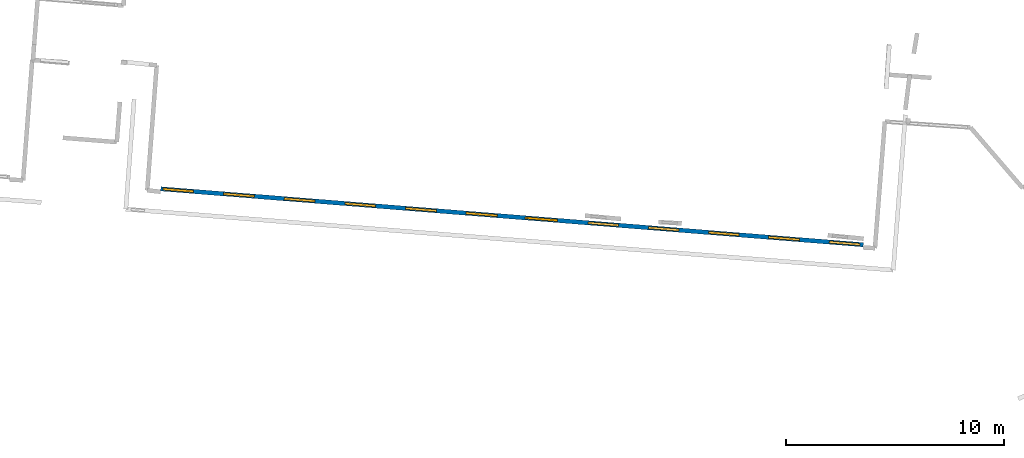
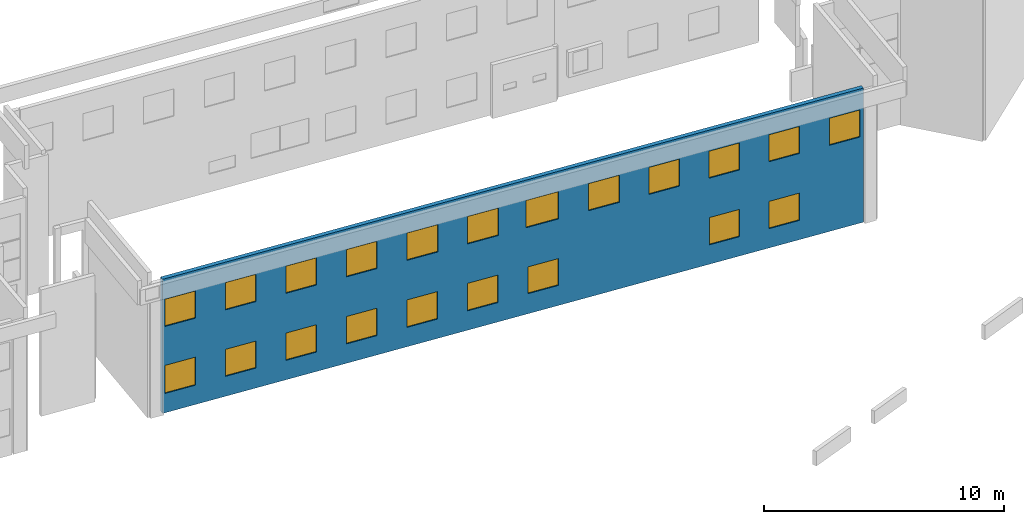
# One storey, part 18 of 27: 21 windows, 1 wall, 21 openings.
"""IFC2X3 building model written with IfcOpenShell, lengths in metres."""

from ifc_helpers import new_model, entity, si_unit, converted_unit, derived_unit, direction, frame, frame_2d, origin, origin_2d_with_axis, place, context, subcontext, project, spatial, polyline, rectangle, outline, extrude, source, transform, mapped, material, layer, layer_set, layer_usage, type_object, type_shapes, element, fill, save


model = new_model("IFC2X3")

# Units and contexts
model_context = context("Model", 3, precision=1e-05, world=origin(), true_north=direction((0.0, 1.0)))
body_context = subcontext(model_context, "Body", "Model", "MODEL_VIEW")
ifc_project = project(units=[si_unit("LENGTHUNIT", "METRE"), si_unit("AREAUNIT", "SQUARE_METRE"), si_unit("VOLUMEUNIT", "CUBIC_METRE"), converted_unit("PLANEANGLEUNIT", "DEGREE", entity("IfcRatioMeasure", 0.0174532925199433), si_unit("PLANEANGLEUNIT", "RADIAN"), dimensions=[0, 0, 0, 0, 0, 0, 0]), si_unit("MASSUNIT", "GRAM", prefix="KILO"), derived_unit("MASSDENSITYUNIT", [(si_unit("MASSUNIT", "GRAM", prefix="KILO"), 1), (si_unit("LENGTHUNIT", "METRE"), -3)]), derived_unit("MOMENTOFINERTIAUNIT", [(si_unit("LENGTHUNIT", "METRE"), 4)]), si_unit("TIMEUNIT", "SECOND"), si_unit("FREQUENCYUNIT", "HERTZ"), si_unit("THERMODYNAMICTEMPERATUREUNIT", "DEGREE_CELSIUS"), derived_unit("THERMALTRANSMITTANCEUNIT", [(si_unit("MASSUNIT", "GRAM", prefix="KILO"), 1), (si_unit("THERMODYNAMICTEMPERATUREUNIT", "KELVIN"), -1), (si_unit("TIMEUNIT", "SECOND"), -3)]), derived_unit("VOLUMETRICFLOWRATEUNIT", [(si_unit("LENGTHUNIT", "METRE"), 3), (si_unit("TIMEUNIT", "SECOND"), -1)]), si_unit("ELECTRICCURRENTUNIT", "AMPERE"), si_unit("ELECTRICVOLTAGEUNIT", "VOLT"), si_unit("POWERUNIT", "WATT"), si_unit("FORCEUNIT", "NEWTON", prefix="KILO"), si_unit("ILLUMINANCEUNIT", "LUX"), si_unit("LUMINOUSFLUXUNIT", "LUMEN"), si_unit("LUMINOUSINTENSITYUNIT", "CANDELA"), derived_unit("USERDEFINED", [(si_unit("MASSUNIT", "GRAM", prefix="KILO"), -1), (si_unit("LENGTHUNIT", "METRE"), -2), (si_unit("TIMEUNIT", "SECOND"), 3), (si_unit("LUMINOUSFLUXUNIT", "LUMEN"), 1)]), derived_unit("LINEARVELOCITYUNIT", [(si_unit("LENGTHUNIT", "METRE"), 1), (si_unit("TIMEUNIT", "SECOND"), -1)]), si_unit("PRESSUREUNIT", "PASCAL"), derived_unit("USERDEFINED", [(si_unit("LENGTHUNIT", "METRE"), -2), (si_unit("MASSUNIT", "GRAM", prefix="KILO"), 1), (si_unit("TIMEUNIT", "SECOND"), -2)]), derived_unit("LINEARFORCEUNIT", [(si_unit("MASSUNIT", "GRAM", prefix="KILO"), 1), (si_unit("LENGTHUNIT", "METRE"), 1), (si_unit("TIMEUNIT", "SECOND"), -2), (si_unit("LENGTHUNIT", "METRE"), -1)]), derived_unit("PLANARFORCEUNIT", [(si_unit("MASSUNIT", "GRAM", prefix="KILO"), 1), (si_unit("LENGTHUNIT", "METRE"), 1), (si_unit("TIMEUNIT", "SECOND"), -2), (si_unit("LENGTHUNIT", "METRE"), -2)])], contexts=[model_context])

# Site, building, storey
placement = place(None, origin())
site = spatial("IfcSite", under=ifc_project, at=placement, CompositionType="ELEMENT")
building = spatial("IfcBuilding", under=site, at=placement, CompositionType="ELEMENT")
storey_placement = place(placement, frame((0.0, 0.0, -61.043098449707)))
storey = spatial("IfcBuildingStorey", under=building, at=storey_placement, Name="level_-61.043098", CompositionType="ELEMENT", Elevation=-61.043098449707)

# Wall, openings, windows
ifc_material_1 = material(Name="Default wall")
ifc_layer = layer(ifc_material_1, 0.2)
ifc_layer_set = layer_set([ifc_layer], Name="wall_thickness_0.2000")
ifc_layer_usage = layer_usage(ifc_layer_set, "AXIS2", "POSITIVE", -0.1)
wall_type = type_object("IfcWallType", Name="wall_thickness_0.2000", PredefinedType="STANDARD", material=ifc_layer_set)
wall_placement = place(storey_placement, frame((-30.6934941233889, -16.4458057543927, 0.0), z_axis=(0.0, 0.0, 1.0), x_axis=(0.996845104750756, -0.0793715133688069, 0.0)))
wall = element("IfcWallStandardCase", 1, at=wall_placement, inside=storey, type_object=wall_type, material=ifc_layer_usage, Name="Wall:955", ObjectType="Wall", context=body_context, shape_type="SweptSolid", body=[
    extrude(outline(polyline([(32.3901609688937, -0.1), (32.3901609688937, 0.1), (0.0, 0.1), (0.0, -0.1), (32.3901609688937, -0.1)])), origin(), (0.0, 0.0, 1.0), 6.83392333984375),
])
opening_1_placement = place(wall_placement, frame((11.2866592142444, -0.1, 0.986843109130859)))
opening_1 = element("IfcOpeningElement", 2, at=opening_1_placement, cuts=wall, Name="Opening : 1425 x 1400 : 111", ObjectType="Opening", context=body_context, shape_type="SweptSolid", body=[
    extrude(rectangle(XDim=1.425, YDim=1.4, at=frame_2d((0.7, 0.7125), x_axis=(0.0, 1.0))), frame((0.0, 0.0, 0.0), z_axis=(0.0, 1.0, 0.0), x_axis=(0.0, 0.0, 1.0)), (0.0, 0.0, 1.0), 0.2),
])
opening_2_placement = place(wall_placement, frame((5.69901006299616, -0.1, 0.989467620849609)))
opening_2 = element("IfcOpeningElement", 3, at=opening_2_placement, cuts=wall, Name="Opening : 1415 x 1390 : 112", ObjectType="Opening", context=body_context, shape_type="SweptSolid", body=[
    extrude(rectangle(XDim=1.415, YDim=1.39, at=frame_2d((0.695, 0.7075), x_axis=(0.0, 1.0))), frame((0.0, 0.0, 0.0), z_axis=(0.0, 1.0, 0.0), x_axis=(0.0, 0.0, 1.0)), (0.0, 0.0, 1.0), 0.2),
])
opening_3_placement = place(wall_placement, frame((5.69400849443347, -0.1, 4.40446853637695)))
opening_3 = element("IfcOpeningElement", 4, at=opening_3_placement, cuts=wall, Name="Opening : 1410 x 1385 : 113", ObjectType="Opening", context=body_context, shape_type="SweptSolid", body=[
    extrude(rectangle(XDim=1.41, YDim=1.385, at=frame_2d((0.6925, 0.705), x_axis=(0.0, 1.0))), frame((0.0, 0.0, 0.0), z_axis=(0.0, 1.0, 0.0), x_axis=(0.0, 0.0, 1.0)), (0.0, 0.0, 1.0), 0.2),
])
opening_4_placement = place(wall_placement, frame((0.0990633938291362, -0.1, 4.39946746826172)))
opening_4 = element("IfcOpeningElement", 5, at=opening_4_placement, cuts=wall, Name="Opening : 1410 x 1385 : 114", ObjectType="Opening", context=body_context, shape_type="SweptSolid", body=[
    extrude(rectangle(XDim=1.41, YDim=1.385, at=frame_2d((0.6925, 0.705), x_axis=(0.0, 1.0))), frame((0.0, 0.0, 0.0), z_axis=(0.0, 1.0, 0.0), x_axis=(0.0, 0.0, 1.0)), (0.0, 0.0, 1.0), 0.2),
])
opening_5_placement = place(wall_placement, frame((0.104622034484493, -0.1, 0.984470367431641)))
opening_5 = element("IfcOpeningElement", 6, at=opening_5_placement, cuts=wall, Name="Opening : 1405 x 1430 : 115", ObjectType="Opening", context=body_context, shape_type="SweptSolid", body=[
    extrude(rectangle(XDim=1.405, YDim=1.43, at=frame_2d((0.715, 0.7025), x_axis=(0.0, 1.0))), frame((0.0, 0.0, 0.0), z_axis=(0.0, 1.0, 0.0), x_axis=(0.0, 0.0, 1.0)), (0.0, 0.0, 1.0), 0.2),
])
opening_6_placement = place(wall_placement, frame((2.89900813275086, -0.1, 1.01446914672852)))
opening_6 = element("IfcOpeningElement", 7, at=opening_6_placement, cuts=wall, Name="Opening : 1415 x 1375 : 116", ObjectType="Opening", context=body_context, shape_type="SweptSolid", body=[
    extrude(rectangle(XDim=1.415, YDim=1.375, at=frame_2d((0.6875, 0.7075), x_axis=(0.0, 1.0))), frame((0.0, 0.0, 0.0), z_axis=(0.0, 1.0, 0.0), x_axis=(0.0, 0.0, 1.0)), (0.0, 0.0, 1.0), 0.2),
])
opening_7_placement = place(wall_placement, frame((2.90165812919661, -0.1, 4.4018440246582)))
opening_7 = element("IfcOpeningElement", 8, at=opening_7_placement, cuts=wall, Name="Opening : 1405 x 1390 : 117", ObjectType="Opening", context=body_context, shape_type="SweptSolid", body=[
    extrude(rectangle(XDim=1.405, YDim=1.39, at=frame_2d((0.695, 0.7025), x_axis=(0.0, 1.0))), frame((0.0, 0.0, 0.0), z_axis=(0.0, 1.0, 0.0), x_axis=(0.0, 0.0, 1.0)), (0.0, 0.0, 1.0), 0.2),
])
opening_8_placement = place(wall_placement, frame((8.49665851979337, -0.1, 4.4018440246582)))
opening_8 = element("IfcOpeningElement", 9, at=opening_8_placement, cuts=wall, Name="Opening : 1415 x 1390 : 118", ObjectType="Opening", context=body_context, shape_type="SweptSolid", body=[
    extrude(rectangle(XDim=1.415, YDim=1.39, at=frame_2d((0.695, 0.7075), x_axis=(0.0, 1.0))), frame((0.0, 0.0, 0.0), z_axis=(0.0, 1.0, 0.0), x_axis=(0.0, 0.0, 1.0)), (0.0, 0.0, 1.0), 0.2),
])
opening_9_placement = place(wall_placement, frame((11.291658881476, -0.1, 4.4018440246582)))
opening_9 = element("IfcOpeningElement", 10, at=opening_9_placement, cuts=wall, Name="Opening : 1430 x 1390 : 119", ObjectType="Opening", context=body_context, shape_type="SweptSolid", body=[
    extrude(rectangle(XDim=1.43, YDim=1.39, at=frame_2d((0.695, 0.715), x_axis=(0.0, 1.0))), frame((0.0, 0.0, 0.0), z_axis=(0.0, 1.0, 0.0), x_axis=(0.0, 0.0, 1.0)), (0.0, 0.0, 1.0), 0.2),
])
opening_10_placement = place(wall_placement, frame((14.0816575232067, -0.1, 4.39684295654297)))
opening_10 = element("IfcOpeningElement", 11, at=opening_10_placement, cuts=wall, Name="Opening : 1440 x 1395 : 120", ObjectType="Opening", context=body_context, shape_type="SweptSolid", body=[
    extrude(rectangle(XDim=1.44, YDim=1.395, at=frame_2d((0.6975, 0.72), x_axis=(0.0, 1.0))), frame((0.0, 0.0, 0.0), z_axis=(0.0, 1.0, 0.0), x_axis=(0.0, 0.0, 1.0)), (0.0, 0.0, 1.0), 0.2),
])
opening_11_placement = place(wall_placement, frame((16.7966583044675, -0.1, 4.40684509277344)))
opening_11 = element("IfcOpeningElement", 12, at=opening_11_placement, cuts=wall, Name="Opening : 1505 x 1390 : 121", ObjectType="Opening", context=body_context, shape_type="SweptSolid", body=[
    extrude(rectangle(XDim=1.505, YDim=1.39, at=frame_2d((0.695, 0.7525), x_axis=(0.0, 1.0))), frame((0.0, 0.0, 0.0), z_axis=(0.0, 1.0, 0.0), x_axis=(0.0, 0.0, 1.0)), (0.0, 0.0, 1.0), 0.2),
])
opening_12_placement = place(wall_placement, frame((19.6916569154981, -0.1, 4.40684509277344)))
opening_12 = element("IfcOpeningElement", 13, at=opening_12_placement, cuts=wall, Name="Opening : 1415 x 1380 : 122", ObjectType="Opening", context=body_context, shape_type="SweptSolid", body=[
    extrude(rectangle(XDim=1.415, YDim=1.38, at=frame_2d((0.69, 0.7075), x_axis=(0.0, 1.0))), frame((0.0, 0.0, 0.0), z_axis=(0.0, 1.0, 0.0), x_axis=(0.0, 0.0, 1.0)), (0.0, 0.0, 1.0), 0.2),
])
opening_13_placement = place(wall_placement, frame((22.4816576099492, -0.1, 4.39684295654297)))
opening_13 = element("IfcOpeningElement", 14, at=opening_13_placement, cuts=wall, Name="Opening : 1410 x 1375 : 123", ObjectType="Opening", context=body_context, shape_type="SweptSolid", body=[
    extrude(rectangle(XDim=1.41, YDim=1.375, at=frame_2d((0.6875, 0.705), x_axis=(0.0, 1.0))), frame((0.0, 0.0, 0.0), z_axis=(0.0, 1.0, 0.0), x_axis=(0.0, 0.0, 1.0)), (0.0, 0.0, 1.0), 0.2),
])
opening_14_placement = place(wall_placement, frame((25.2616599206027, -0.1, 4.38684463500977)))
opening_14 = element("IfcOpeningElement", 15, at=opening_14_placement, cuts=wall, Name="Opening : 1400 x 1375 : 124", ObjectType="Opening", context=body_context, shape_type="SweptSolid", body=[
    extrude(rectangle(XDim=1.4, YDim=1.375, at=frame_2d((0.6875, 0.7), x_axis=(0.0, 1.0))), frame((0.0, 0.0, 0.0), z_axis=(0.0, 1.0, 0.0), x_axis=(0.0, 0.0, 1.0)), (0.0, 0.0, 1.0), 0.2),
])
opening_15_placement = place(wall_placement, frame((28.0166580397159, -0.1, 4.391845703125)))
opening_15 = element("IfcOpeningElement", 16, at=opening_15_placement, cuts=wall, Name="Opening : 1425 x 1375 : 125", ObjectType="Opening", context=body_context, shape_type="SweptSolid", body=[
    extrude(rectangle(XDim=1.425, YDim=1.375, at=frame_2d((0.6875, 0.7125), x_axis=(0.0, 1.0))), frame((0.0, 0.0, 0.0), z_axis=(0.0, 1.0, 0.0), x_axis=(0.0, 0.0, 1.0)), (0.0, 0.0, 1.0), 0.2),
])
opening_16_placement = place(wall_placement, frame((30.8216577358616, -0.1, 4.38684463500977)))
opening_16 = element("IfcOpeningElement", 17, at=opening_16_placement, cuts=wall, Name="Opening : 1415 x 1380 : 126", ObjectType="Opening", context=body_context, shape_type="SweptSolid", body=[
    extrude(rectangle(XDim=1.415, YDim=1.38, at=frame_2d((0.69, 0.7075), x_axis=(0.0, 1.0))), frame((0.0, 0.0, 0.0), z_axis=(0.0, 1.0, 0.0), x_axis=(0.0, 0.0, 1.0)), (0.0, 0.0, 1.0), 0.2),
])
opening_17_placement = place(wall_placement, frame((8.49665851979337, -0.1, 0.986843109130859)))
opening_17 = element("IfcOpeningElement", 18, at=opening_17_placement, cuts=wall, Name="Opening : 1415 x 1395 : 127", ObjectType="Opening", context=body_context, shape_type="SweptSolid", body=[
    extrude(rectangle(XDim=1.415, YDim=1.395, at=frame_2d((0.6975, 0.7075), x_axis=(0.0, 1.0))), frame((0.0, 0.0, 0.0), z_axis=(0.0, 1.0, 0.0), x_axis=(0.0, 0.0, 1.0)), (0.0, 0.0, 1.0), 0.2),
])
opening_18_placement = place(wall_placement, frame((14.0816575232067, -0.1, 0.986843109130859)))
opening_18 = element("IfcOpeningElement", 19, at=opening_18_placement, cuts=wall, Name="Opening : 1430 x 1400 : 128", ObjectType="Opening", context=body_context, shape_type="SweptSolid", body=[
    extrude(rectangle(XDim=1.43, YDim=1.4, at=frame_2d((0.7, 0.715), x_axis=(0.0, 1.0))), frame((0.0, 0.0, 0.0), z_axis=(0.0, 1.0, 0.0), x_axis=(0.0, 0.0, 1.0)), (0.0, 0.0, 1.0), 0.2),
])
opening_19_placement = place(wall_placement, frame((16.8916578372496, -0.1, 1.02184295654297)))
opening_19 = element("IfcOpeningElement", 20, at=opening_19_placement, cuts=wall, Name="Opening : 1405 x 1365 : 129", ObjectType="Opening", context=body_context, shape_type="SweptSolid", body=[
    extrude(rectangle(XDim=1.405, YDim=1.365, at=frame_2d((0.6825, 0.7025), x_axis=(0.0, 1.0))), frame((0.0, 0.0, 0.0), z_axis=(0.0, 1.0, 0.0), x_axis=(0.0, 0.0, 1.0)), (0.0, 0.0, 1.0), 0.2),
])
opening_20_placement = place(wall_placement, frame((25.2716564030691, -0.1, 0.986843109130859)))
opening_20 = element("IfcOpeningElement", 21, at=opening_20_placement, cuts=wall, Name="Opening : 1395 x 1390 : 130", ObjectType="Opening", context=body_context, shape_type="SweptSolid", body=[
    extrude(rectangle(XDim=1.395, YDim=1.39, at=frame_2d((0.695, 0.6975), x_axis=(0.0, 1.0))), frame((0.0, 0.0, 0.0), z_axis=(0.0, 1.0, 0.0), x_axis=(0.0, 0.0, 1.0)), (0.0, 0.0, 1.0), 0.2),
])
opening_21_placement = place(wall_placement, frame((28.0266583248446, -0.1, 0.981842041015625)))
opening_21 = element("IfcOpeningElement", 22, at=opening_21_placement, cuts=wall, Name="Opening : 1420 x 1390 : 131", ObjectType="Opening", context=body_context, shape_type="SweptSolid", body=[
    extrude(rectangle(XDim=1.42, YDim=1.39, at=frame_2d((0.695, 0.71), x_axis=(0.0, 1.0))), frame((0.0, 0.0, 0.0), z_axis=(0.0, 1.0, 0.0), x_axis=(0.0, 0.0, 1.0)), (0.0, 0.0, 1.0), 0.2),
])
ifc_material_2 = material(Name="Window Default")
window_style_1 = type_object("IfcWindowStyle", Name="Window : 1420 x 1390mm", ConstructionType="NOTDEFINED", OperationType="NOTDEFINED", ParameterTakesPrecedence=False, Sizeable=False, material=ifc_material_2)
shared_shape_1 = source(origin(), body_context, "Body", "SweptSolid", [
    extrude(rectangle(XDim=0.1, YDim=1.42, at=origin_2d_with_axis()), frame((0.71, 0.1, 0.0), z_axis=(0.0, 0.0, 1.0), x_axis=(0.0, 1.0, 0.0)), (0.0, 0.0, 1.0), 1.39),
])
type_shapes(window_style_1, [shared_shape_1])
window_1_placement = place(opening_21_placement, origin())
window_1 = element("IfcWindow", 23, at=window_1_placement, inside=storey, type_object=window_style_1, Name="Window : 1420 x 1390mm : 119", ObjectType="Window : 1420 x 1390mm", OverallHeight=1.39, OverallWidth=1.42, context=body_context, shape_type="MappedRepresentation", body=[
    mapped(shared_shape_1, transform((0.0, 0.0, 0.0), scale=1.0)),
])
fill(opening_21, window_1)
window_style_2 = type_object("IfcWindowStyle", Name="Window : 1425 x 1400mm", ConstructionType="NOTDEFINED", OperationType="NOTDEFINED", ParameterTakesPrecedence=False, Sizeable=False, material=ifc_material_2)
shared_shape_2 = source(origin(), body_context, "Body", "SweptSolid", [
    extrude(rectangle(XDim=0.1, YDim=1.425, at=origin_2d_with_axis()), frame((0.7125, 0.1, 0.0), z_axis=(0.0, 0.0, 1.0), x_axis=(0.0, 1.0, 0.0)), (0.0, 0.0, 1.0), 1.4),
])
type_shapes(window_style_2, [shared_shape_2])
window_2_placement = place(opening_1_placement, origin())
window_2 = element("IfcWindow", 24, at=window_2_placement, inside=storey, type_object=window_style_2, Name="Window : 1425 x 1400mm : 99", ObjectType="Window : 1425 x 1400mm", OverallHeight=1.4, OverallWidth=1.425, context=body_context, shape_type="MappedRepresentation", body=[
    mapped(shared_shape_2, transform((0.0, 0.0, 0.0), scale=1.0)),
])
fill(opening_1, window_2)
window_style_3 = type_object("IfcWindowStyle", Name="Window : 1430 x 1390mm", ConstructionType="NOTDEFINED", OperationType="NOTDEFINED", ParameterTakesPrecedence=False, Sizeable=False, material=ifc_material_2)
shared_shape_3 = source(origin(), body_context, "Body", "SweptSolid", [
    extrude(rectangle(XDim=0.1, YDim=1.43, at=origin_2d_with_axis()), frame((0.715, 0.1, 0.0), z_axis=(0.0, 0.0, 1.0), x_axis=(0.0, 1.0, 0.0)), (0.0, 0.0, 1.0), 1.39),
])
type_shapes(window_style_3, [shared_shape_3])
window_3_placement = place(opening_9_placement, origin())
window_3 = element("IfcWindow", 25, at=window_3_placement, inside=storey, type_object=window_style_3, Name="Window : 1430 x 1390mm : 107", ObjectType="Window : 1430 x 1390mm", OverallHeight=1.39, OverallWidth=1.43, context=body_context, shape_type="MappedRepresentation", body=[
    mapped(shared_shape_3, transform((0.0, 0.0, 0.0), scale=1.0)),
])
fill(opening_9, window_3)
window_style_4 = type_object("IfcWindowStyle", Name="Window : 1415 x 1375mm", ConstructionType="NOTDEFINED", OperationType="NOTDEFINED", ParameterTakesPrecedence=False, Sizeable=False, material=ifc_material_2)
shared_shape_4 = source(origin(), body_context, "Body", "SweptSolid", [
    extrude(rectangle(XDim=0.1, YDim=1.415, at=origin_2d_with_axis()), frame((0.7075, 0.1, 0.0), z_axis=(0.0, 0.0, 1.0), x_axis=(0.0, 1.0, 0.0)), (0.0, 0.0, 1.0), 1.375),
])
type_shapes(window_style_4, [shared_shape_4])
window_4_placement = place(opening_6_placement, origin())
window_4 = element("IfcWindow", 26, at=window_4_placement, inside=storey, type_object=window_style_4, Name="Window : 1415 x 1375mm : 104", ObjectType="Window : 1415 x 1375mm", OverallHeight=1.375, OverallWidth=1.415, context=body_context, shape_type="MappedRepresentation", body=[
    mapped(shared_shape_4, transform((0.0, 0.0, 0.0), scale=1.0)),
])
fill(opening_6, window_4)
window_style_5 = type_object("IfcWindowStyle", Name="Window : 1405 x 1365mm", ConstructionType="NOTDEFINED", OperationType="NOTDEFINED", ParameterTakesPrecedence=False, Sizeable=False, material=ifc_material_2)
shared_shape_5 = source(origin(), body_context, "Body", "SweptSolid", [
    extrude(rectangle(XDim=0.1, YDim=1.405, at=origin_2d_with_axis()), frame((0.7025, 0.1, 0.0), z_axis=(0.0, 0.0, 1.0), x_axis=(0.0, 1.0, 0.0)), (0.0, 0.0, 1.0), 1.365),
])
type_shapes(window_style_5, [shared_shape_5])
window_5_placement = place(opening_19_placement, origin())
window_5 = element("IfcWindow", 27, at=window_5_placement, inside=storey, type_object=window_style_5, Name="Window : 1405 x 1365mm : 117", ObjectType="Window : 1405 x 1365mm", OverallHeight=1.365, OverallWidth=1.405, context=body_context, shape_type="MappedRepresentation", body=[
    mapped(shared_shape_5, transform((0.0, 0.0, 0.0), scale=1.0)),
])
fill(opening_19, window_5)
window_style_6 = type_object("IfcWindowStyle", Name="Window : 1415 x 1395mm", ConstructionType="NOTDEFINED", OperationType="NOTDEFINED", ParameterTakesPrecedence=False, Sizeable=False, material=ifc_material_2)
shared_shape_6 = source(origin(), body_context, "Body", "SweptSolid", [
    extrude(rectangle(XDim=0.1, YDim=1.415, at=origin_2d_with_axis()), frame((0.7075, 0.1, 0.0), z_axis=(0.0, 0.0, 1.0), x_axis=(0.0, 1.0, 0.0)), (0.0, 0.0, 1.0), 1.395),
])
type_shapes(window_style_6, [shared_shape_6])
window_6_placement = place(opening_17_placement, origin())
window_6 = element("IfcWindow", 28, at=window_6_placement, inside=storey, type_object=window_style_6, Name="Window : 1415 x 1395mm : 115", ObjectType="Window : 1415 x 1395mm", OverallHeight=1.395, OverallWidth=1.415, context=body_context, shape_type="MappedRepresentation", body=[
    mapped(shared_shape_6, transform((0.0, 0.0, 0.0), scale=1.0)),
])
fill(opening_17, window_6)
window_style_7 = type_object("IfcWindowStyle", Name="Window : 1415 x 1390mm", ConstructionType="NOTDEFINED", OperationType="NOTDEFINED", ParameterTakesPrecedence=False, Sizeable=False, material=ifc_material_2)
shared_shape_7 = source(origin(), body_context, "Body", "SweptSolid", [
    extrude(rectangle(XDim=0.1, YDim=1.415, at=origin_2d_with_axis()), frame((0.7075, 0.1, 0.0), z_axis=(0.0, 0.0, 1.0), x_axis=(0.0, 1.0, 0.0)), (0.0, 0.0, 1.0), 1.39),
])
type_shapes(window_style_7, [shared_shape_7])
window_7_placement = place(opening_2_placement, origin())
window_7 = element("IfcWindow", 29, at=window_7_placement, inside=storey, type_object=window_style_7, Name="Window : 1415 x 1390mm : 100", ObjectType="Window : 1415 x 1390mm", OverallHeight=1.39, OverallWidth=1.415, context=body_context, shape_type="MappedRepresentation", body=[
    mapped(shared_shape_7, transform((0.0, 0.0, 0.0), scale=1.0)),
])
fill(opening_2, window_7)
window_8_placement = place(opening_8_placement, origin())
window_8 = element("IfcWindow", 30, at=window_8_placement, inside=storey, type_object=window_style_7, Name="Window : 1415 x 1390mm : 106", ObjectType="Window : 1415 x 1390mm", OverallHeight=1.39, OverallWidth=1.415, context=body_context, shape_type="MappedRepresentation", body=[
    mapped(shared_shape_7, transform((0.0, 0.0, 0.0), scale=1.0)),
])
fill(opening_8, window_8)
window_style_8 = type_object("IfcWindowStyle", Name="Window : 1410 x 1385mm", ConstructionType="NOTDEFINED", OperationType="NOTDEFINED", ParameterTakesPrecedence=False, Sizeable=False, material=ifc_material_2)
shared_shape_8 = source(origin(), body_context, "Body", "SweptSolid", [
    extrude(rectangle(XDim=0.1, YDim=1.41, at=origin_2d_with_axis()), frame((0.705, 0.1, 0.0), z_axis=(0.0, 0.0, 1.0), x_axis=(0.0, 1.0, 0.0)), (0.0, 0.0, 1.0), 1.385),
])
type_shapes(window_style_8, [shared_shape_8])
window_9_placement = place(opening_3_placement, origin())
window_9 = element("IfcWindow", 31, at=window_9_placement, inside=storey, type_object=window_style_8, Name="Window : 1410 x 1385mm : 101", ObjectType="Window : 1410 x 1385mm", OverallHeight=1.385, OverallWidth=1.41, context=body_context, shape_type="MappedRepresentation", body=[
    mapped(shared_shape_8, transform((0.0, 0.0, 0.0), scale=1.0)),
])
fill(opening_3, window_9)
window_10_placement = place(opening_4_placement, origin())
window_10 = element("IfcWindow", 32, at=window_10_placement, inside=storey, type_object=window_style_8, Name="Window : 1410 x 1385mm : 102", ObjectType="Window : 1410 x 1385mm", OverallHeight=1.385, OverallWidth=1.41, context=body_context, shape_type="MappedRepresentation", body=[
    mapped(shared_shape_8, transform((0.0, 0.0, 0.0), scale=1.0)),
])
fill(opening_4, window_10)
window_style_9 = type_object("IfcWindowStyle", Name="Window : 1405 x 1430mm", ConstructionType="NOTDEFINED", OperationType="NOTDEFINED", ParameterTakesPrecedence=False, Sizeable=False, material=ifc_material_2)
shared_shape_9 = source(origin(), body_context, "Body", "SweptSolid", [
    extrude(rectangle(XDim=0.1, YDim=1.405, at=origin_2d_with_axis()), frame((0.7025, 0.1, 0.0), z_axis=(0.0, 0.0, 1.0), x_axis=(0.0, 1.0, 0.0)), (0.0, 0.0, 1.0), 1.43),
])
type_shapes(window_style_9, [shared_shape_9])
window_11_placement = place(opening_5_placement, origin())
window_11 = element("IfcWindow", 33, at=window_11_placement, inside=storey, type_object=window_style_9, Name="Window : 1405 x 1430mm : 103", ObjectType="Window : 1405 x 1430mm", OverallHeight=1.43, OverallWidth=1.405, context=body_context, shape_type="MappedRepresentation", body=[
    mapped(shared_shape_9, transform((0.0, 0.0, 0.0), scale=1.0)),
])
fill(opening_5, window_11)
window_style_10 = type_object("IfcWindowStyle", Name="Window : 1405 x 1390mm", ConstructionType="NOTDEFINED", OperationType="NOTDEFINED", ParameterTakesPrecedence=False, Sizeable=False, material=ifc_material_2)
shared_shape_10 = source(origin(), body_context, "Body", "SweptSolid", [
    extrude(rectangle(XDim=0.1, YDim=1.405, at=origin_2d_with_axis()), frame((0.7025, 0.1, 0.0), z_axis=(0.0, 0.0, 1.0), x_axis=(0.0, 1.0, 0.0)), (0.0, 0.0, 1.0), 1.39),
])
type_shapes(window_style_10, [shared_shape_10])
window_12_placement = place(opening_7_placement, origin())
window_12 = element("IfcWindow", 34, at=window_12_placement, inside=storey, type_object=window_style_10, Name="Window : 1405 x 1390mm : 105", ObjectType="Window : 1405 x 1390mm", OverallHeight=1.39, OverallWidth=1.405, context=body_context, shape_type="MappedRepresentation", body=[
    mapped(shared_shape_10, transform((0.0, 0.0, 0.0), scale=1.0)),
])
fill(opening_7, window_12)
window_style_11 = type_object("IfcWindowStyle", Name="Window : 1440 x 1395mm", ConstructionType="NOTDEFINED", OperationType="NOTDEFINED", ParameterTakesPrecedence=False, Sizeable=False, material=ifc_material_2)
shared_shape_11 = source(origin(), body_context, "Body", "SweptSolid", [
    extrude(rectangle(XDim=0.1, YDim=1.44, at=origin_2d_with_axis()), frame((0.72, 0.1, 0.0), z_axis=(0.0, 0.0, 1.0), x_axis=(0.0, 1.0, 0.0)), (0.0, 0.0, 1.0), 1.395),
])
type_shapes(window_style_11, [shared_shape_11])
window_13_placement = place(opening_10_placement, origin())
window_13 = element("IfcWindow", 35, at=window_13_placement, inside=storey, type_object=window_style_11, Name="Window : 1440 x 1395mm : 108", ObjectType="Window : 1440 x 1395mm", OverallHeight=1.395, OverallWidth=1.44, context=body_context, shape_type="MappedRepresentation", body=[
    mapped(shared_shape_11, transform((0.0, 0.0, 0.0), scale=1.0)),
])
fill(opening_10, window_13)
window_style_12 = type_object("IfcWindowStyle", Name="Window : 1505 x 1390mm", ConstructionType="NOTDEFINED", OperationType="NOTDEFINED", ParameterTakesPrecedence=False, Sizeable=False, material=ifc_material_2)
shared_shape_12 = source(origin(), body_context, "Body", "SweptSolid", [
    extrude(rectangle(XDim=0.1, YDim=1.505, at=origin_2d_with_axis()), frame((0.7525, 0.1, 0.0), z_axis=(0.0, 0.0, 1.0), x_axis=(0.0, 1.0, 0.0)), (0.0, 0.0, 1.0), 1.39),
])
type_shapes(window_style_12, [shared_shape_12])
window_14_placement = place(opening_11_placement, origin())
window_14 = element("IfcWindow", 36, at=window_14_placement, inside=storey, type_object=window_style_12, Name="Window : 1505 x 1390mm : 109", ObjectType="Window : 1505 x 1390mm", OverallHeight=1.39, OverallWidth=1.505, context=body_context, shape_type="MappedRepresentation", body=[
    mapped(shared_shape_12, transform((0.0, 0.0, 0.0), scale=1.0)),
])
fill(opening_11, window_14)
window_style_13 = type_object("IfcWindowStyle", Name="Window : 1415 x 1380mm", ConstructionType="NOTDEFINED", OperationType="NOTDEFINED", ParameterTakesPrecedence=False, Sizeable=False, material=ifc_material_2)
shared_shape_13 = source(origin(), body_context, "Body", "SweptSolid", [
    extrude(rectangle(XDim=0.1, YDim=1.415, at=origin_2d_with_axis()), frame((0.7075, 0.1, 0.0), z_axis=(0.0, 0.0, 1.0), x_axis=(0.0, 1.0, 0.0)), (0.0, 0.0, 1.0), 1.38),
])
type_shapes(window_style_13, [shared_shape_13])
window_15_placement = place(opening_12_placement, origin())
window_15 = element("IfcWindow", 37, at=window_15_placement, inside=storey, type_object=window_style_13, Name="Window : 1415 x 1380mm : 110", ObjectType="Window : 1415 x 1380mm", OverallHeight=1.38, OverallWidth=1.415, context=body_context, shape_type="MappedRepresentation", body=[
    mapped(shared_shape_13, transform((0.0, 0.0, 0.0), scale=1.0)),
])
fill(opening_12, window_15)
window_16_placement = place(opening_16_placement, origin())
window_16 = element("IfcWindow", 38, at=window_16_placement, inside=storey, type_object=window_style_13, Name="Window : 1415 x 1380mm : 114", ObjectType="Window : 1415 x 1380mm", OverallHeight=1.38, OverallWidth=1.415, context=body_context, shape_type="MappedRepresentation", body=[
    mapped(shared_shape_13, transform((0.0, 0.0, 0.0), scale=1.0)),
])
fill(opening_16, window_16)
window_style_14 = type_object("IfcWindowStyle", Name="Window : 1410 x 1375mm", ConstructionType="NOTDEFINED", OperationType="NOTDEFINED", ParameterTakesPrecedence=False, Sizeable=False, material=ifc_material_2)
shared_shape_14 = source(origin(), body_context, "Body", "SweptSolid", [
    extrude(rectangle(XDim=0.1, YDim=1.41, at=origin_2d_with_axis()), frame((0.705, 0.1, 0.0), z_axis=(0.0, 0.0, 1.0), x_axis=(0.0, 1.0, 0.0)), (0.0, 0.0, 1.0), 1.375),
])
type_shapes(window_style_14, [shared_shape_14])
window_17_placement = place(opening_13_placement, origin())
window_17 = element("IfcWindow", 39, at=window_17_placement, inside=storey, type_object=window_style_14, Name="Window : 1410 x 1375mm : 111", ObjectType="Window : 1410 x 1375mm", OverallHeight=1.375, OverallWidth=1.41, context=body_context, shape_type="MappedRepresentation", body=[
    mapped(shared_shape_14, transform((0.0, 0.0, 0.0), scale=1.0)),
])
fill(opening_13, window_17)
window_style_15 = type_object("IfcWindowStyle", Name="Window : 1400 x 1375mm", ConstructionType="NOTDEFINED", OperationType="NOTDEFINED", ParameterTakesPrecedence=False, Sizeable=False, material=ifc_material_2)
shared_shape_15 = source(origin(), body_context, "Body", "SweptSolid", [
    extrude(rectangle(XDim=0.1, YDim=1.4, at=origin_2d_with_axis()), frame((0.7, 0.1, 0.0), z_axis=(0.0, 0.0, 1.0), x_axis=(0.0, 1.0, 0.0)), (0.0, 0.0, 1.0), 1.375),
])
type_shapes(window_style_15, [shared_shape_15])
window_18_placement = place(opening_14_placement, origin())
window_18 = element("IfcWindow", 40, at=window_18_placement, inside=storey, type_object=window_style_15, Name="Window : 1400 x 1375mm : 112", ObjectType="Window : 1400 x 1375mm", OverallHeight=1.375, OverallWidth=1.4, context=body_context, shape_type="MappedRepresentation", body=[
    mapped(shared_shape_15, transform((0.0, 0.0, 0.0), scale=1.0)),
])
fill(opening_14, window_18)
window_style_16 = type_object("IfcWindowStyle", Name="Window : 1425 x 1375mm", ConstructionType="NOTDEFINED", OperationType="NOTDEFINED", ParameterTakesPrecedence=False, Sizeable=False, material=ifc_material_2)
shared_shape_16 = source(origin(), body_context, "Body", "SweptSolid", [
    extrude(rectangle(XDim=0.1, YDim=1.425, at=origin_2d_with_axis()), frame((0.7125, 0.1, 0.0), z_axis=(0.0, 0.0, 1.0), x_axis=(0.0, 1.0, 0.0)), (0.0, 0.0, 1.0), 1.375),
])
type_shapes(window_style_16, [shared_shape_16])
window_19_placement = place(opening_15_placement, origin())
window_19 = element("IfcWindow", 41, at=window_19_placement, inside=storey, type_object=window_style_16, Name="Window : 1425 x 1375mm : 113", ObjectType="Window : 1425 x 1375mm", OverallHeight=1.375, OverallWidth=1.425, context=body_context, shape_type="MappedRepresentation", body=[
    mapped(shared_shape_16, transform((0.0, 0.0, 0.0), scale=1.0)),
])
fill(opening_15, window_19)
window_style_17 = type_object("IfcWindowStyle", Name="Window : 1430 x 1400mm", ConstructionType="NOTDEFINED", OperationType="NOTDEFINED", ParameterTakesPrecedence=False, Sizeable=False, material=ifc_material_2)
shared_shape_17 = source(origin(), body_context, "Body", "SweptSolid", [
    extrude(rectangle(XDim=0.1, YDim=1.43, at=origin_2d_with_axis()), frame((0.715, 0.1, 0.0), z_axis=(0.0, 0.0, 1.0), x_axis=(0.0, 1.0, 0.0)), (0.0, 0.0, 1.0), 1.4),
])
type_shapes(window_style_17, [shared_shape_17])
window_20_placement = place(opening_18_placement, origin())
window_20 = element("IfcWindow", 42, at=window_20_placement, inside=storey, type_object=window_style_17, Name="Window : 1430 x 1400mm : 116", ObjectType="Window : 1430 x 1400mm", OverallHeight=1.4, OverallWidth=1.43, context=body_context, shape_type="MappedRepresentation", body=[
    mapped(shared_shape_17, transform((0.0, 0.0, 0.0), scale=1.0)),
])
fill(opening_18, window_20)
window_style_18 = type_object("IfcWindowStyle", Name="Window : 1395 x 1390mm", ConstructionType="NOTDEFINED", OperationType="NOTDEFINED", ParameterTakesPrecedence=False, Sizeable=False, material=ifc_material_2)
shared_shape_18 = source(origin(), body_context, "Body", "SweptSolid", [
    extrude(rectangle(XDim=0.1, YDim=1.395, at=origin_2d_with_axis()), frame((0.6975, 0.1, 0.0), z_axis=(0.0, 0.0, 1.0), x_axis=(0.0, 1.0, 0.0)), (0.0, 0.0, 1.0), 1.39),
])
type_shapes(window_style_18, [shared_shape_18])
window_21_placement = place(opening_20_placement, origin())
window_21 = element("IfcWindow", 43, at=window_21_placement, inside=storey, type_object=window_style_18, Name="Window : 1395 x 1390mm : 118", ObjectType="Window : 1395 x 1390mm", OverallHeight=1.39, OverallWidth=1.395, context=body_context, shape_type="MappedRepresentation", body=[
    mapped(shared_shape_18, transform((0.0, 0.0, 0.0), scale=1.0)),
])
fill(opening_20, window_21)

save(model, "model.ifc")
